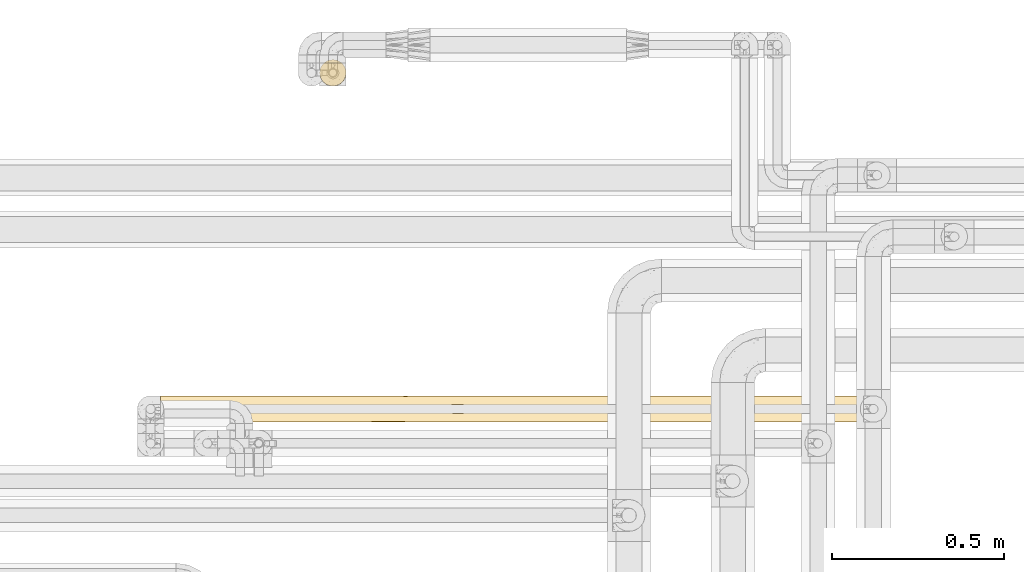
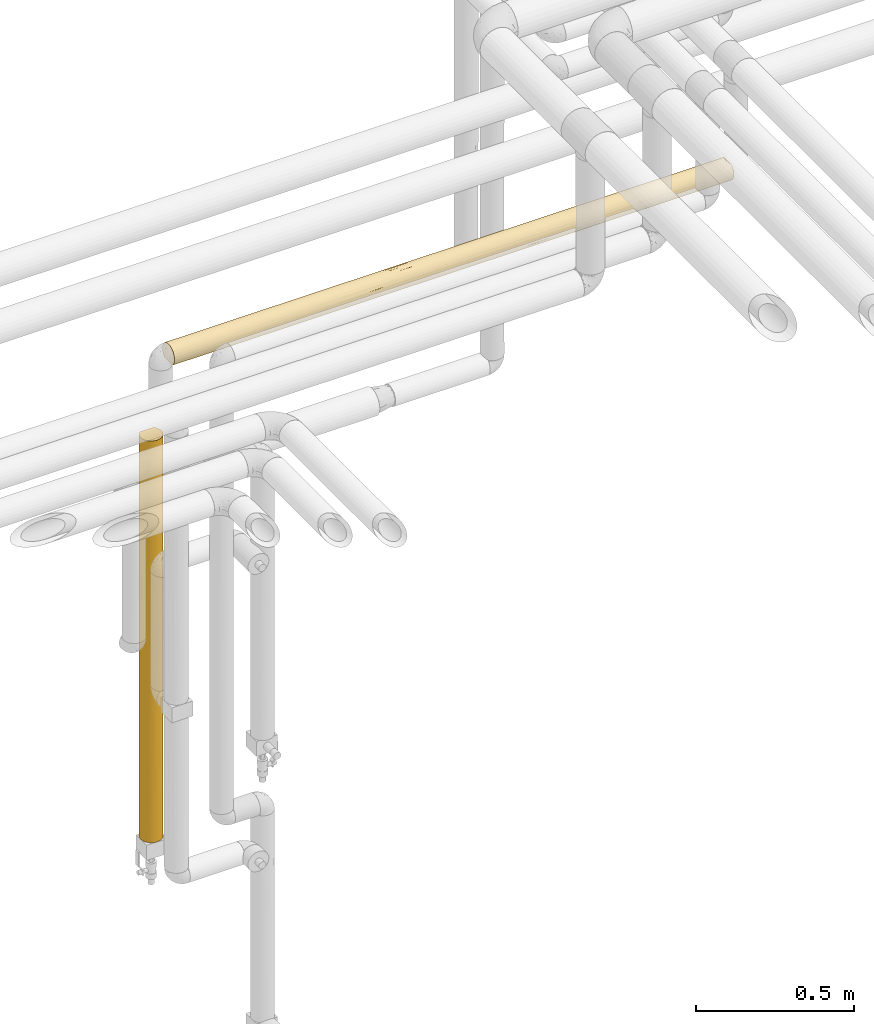
# One storey, part 43 of 827: 2 coverings.
"""IFC2X3 building model written with IfcOpenShell, lengths in millimetres."""

from ifc_helpers import new_model, entity, si_unit, converted_unit, derived_unit, direction, frame, origin, place, context, subcontext, project, spatial, faceted_brep, element, save


model = new_model("IFC2X3")

# Units and contexts
model_context = context("Model", 3, precision=0.01, world=origin(), true_north=direction((6.12303176911189e-17, 1.0)))
body_context = subcontext(model_context, "Body", "Model", "MODEL_VIEW")
ifc_project = project(units=[si_unit("LENGTHUNIT", "METRE", prefix="MILLI"), si_unit("AREAUNIT", "SQUARE_METRE"), si_unit("VOLUMEUNIT", "CUBIC_METRE"), converted_unit("PLANEANGLEUNIT", "DEGREE", entity("IfcRatioMeasure", 0.0174532925199433), si_unit("PLANEANGLEUNIT", "RADIAN"), dimensions=[0, 0, 0, 0, 0, 0, 0]), si_unit("MASSUNIT", "GRAM", prefix="KILO"), derived_unit("MASSDENSITYUNIT", [(si_unit("MASSUNIT", "GRAM", prefix="KILO"), 1), (si_unit("LENGTHUNIT", "METRE"), -3)]), derived_unit("MOMENTOFINERTIAUNIT", [(si_unit("LENGTHUNIT", "METRE"), 4)]), si_unit("TIMEUNIT", "SECOND"), si_unit("FREQUENCYUNIT", "HERTZ"), si_unit("THERMODYNAMICTEMPERATUREUNIT", "DEGREE_CELSIUS"), derived_unit("THERMALTRANSMITTANCEUNIT", [(si_unit("MASSUNIT", "GRAM", prefix="KILO"), 1), (si_unit("THERMODYNAMICTEMPERATUREUNIT", "KELVIN"), -1), (si_unit("TIMEUNIT", "SECOND"), -3)]), derived_unit("VOLUMETRICFLOWRATEUNIT", [(si_unit("LENGTHUNIT", "METRE"), 3), (si_unit("TIMEUNIT", "SECOND"), -1)]), derived_unit("MASSFLOWRATEUNIT", [(si_unit("MASSUNIT", "GRAM", prefix="KILO"), 1), (si_unit("TIMEUNIT", "SECOND"), -1)]), derived_unit("ROTATIONALFREQUENCYUNIT", [(si_unit("TIMEUNIT", "SECOND"), -1)]), si_unit("ELECTRICCURRENTUNIT", "AMPERE"), si_unit("ELECTRICVOLTAGEUNIT", "VOLT"), si_unit("POWERUNIT", "WATT"), si_unit("FORCEUNIT", "NEWTON", prefix="KILO"), si_unit("ILLUMINANCEUNIT", "LUX"), si_unit("LUMINOUSFLUXUNIT", "LUMEN"), si_unit("LUMINOUSINTENSITYUNIT", "CANDELA"), derived_unit("USERDEFINED", [(si_unit("MASSUNIT", "GRAM", prefix="KILO"), -1), (si_unit("LENGTHUNIT", "METRE"), -2), (si_unit("TIMEUNIT", "SECOND"), 3), (si_unit("LUMINOUSFLUXUNIT", "LUMEN"), 1)]), derived_unit("LINEARVELOCITYUNIT", [(si_unit("LENGTHUNIT", "METRE"), 1), (si_unit("TIMEUNIT", "SECOND"), -1)]), si_unit("PRESSUREUNIT", "PASCAL"), derived_unit("USERDEFINED", [(si_unit("LENGTHUNIT", "METRE"), -2), (si_unit("MASSUNIT", "GRAM", prefix="KILO"), 1), (si_unit("TIMEUNIT", "SECOND"), -2)]), derived_unit("LINEARFORCEUNIT", [(si_unit("MASSUNIT", "GRAM", prefix="KILO"), 1), (si_unit("LENGTHUNIT", "METRE"), 1), (si_unit("TIMEUNIT", "SECOND"), -2), (si_unit("LENGTHUNIT", "METRE"), -1)]), derived_unit("PLANARFORCEUNIT", [(si_unit("MASSUNIT", "GRAM", prefix="KILO"), 1), (si_unit("LENGTHUNIT", "METRE"), 1), (si_unit("TIMEUNIT", "SECOND"), -2), (si_unit("LENGTHUNIT", "METRE"), -2)])], contexts=[model_context])

# Site, building, storey
site_placement = place(None, origin())
site = spatial("IfcSite", under=ifc_project, at=site_placement, CompositionType="ELEMENT")
building_placement = place(site_placement, origin())
building = spatial("IfcBuilding", under=site, at=building_placement, CompositionType="ELEMENT")
storey_placement = place(building_placement, frame((0.0, 0.0, 28200.0)))
storey = spatial("IfcBuildingStorey", under=building, at=storey_placement, Name="08", CompositionType="ELEMENT", Elevation=28200.0)

# Coverings
covering_1_placement = place(storey_placement, frame((35016.04, 19373.44, 367.5)))
element("IfcCovering", 1, at=covering_1_placement, inside=storey, Name=":ADSK_", ObjectType=":ADSK_", PredefinedType="INSULATION", context=body_context, shape_type="Brep", body=[
    faceted_brep([(73.25, 20.8, 1553.4), (77.09, 30.06, 1553.4), (78.4, 40.0, 1553.4), (77.51, 48.2, 1553.4), (74.9, 56.01, 1553.4), (70.68, 63.08, 1553.4), (65.05, 69.1, 1553.4), (14.94, 69.1, 1553.4), (9.31, 63.08, 1553.4), (5.09, 56.01, 1553.4), (2.48, 48.2, 1553.4), (1.6, 40.0, 1553.4), (2.9, 30.06, 1553.4), (6.74, 20.8, 1553.4), (12.84, 12.84, 1553.4), (20.8, 6.74, 1553.4), (30.06, 2.9, 1553.4), (40.0, 1.6, 1553.4), (49.93, 2.9, 1553.4), (59.2, 6.74, 1553.4), (67.15, 12.84, 1553.4), (73.25, 20.8, 0.0), (67.15, 12.84, 0.0), (59.2, 6.74, 0.0), (49.93, 2.9, 0.0), (40.0, 1.6, 0.0), (30.06, 2.9, 0.0), (20.8, 6.74, 0.0), (12.84, 12.84, 0.0), (6.74, 20.8, 0.0), (2.9, 30.06, 0.0), (1.6, 40.0, 0.0), (2.9, 49.93, 0.0), (6.74, 59.2, 0.0), (12.84, 67.15, 0.0), (20.8, 73.25, 0.0), (30.06, 77.09, 0.0), (40.0, 78.4, 0.0), (49.93, 77.09, 0.0), (59.2, 73.25, 0.0), (67.15, 67.15, 0.0), (73.25, 59.2, 0.0), (77.09, 49.93, 0.0), (78.4, 40.0, 0.0), (77.09, 30.06, 0.0), (75.47, 54.69, 266.77), (48.24, 77.5, 1219.54), (50.46, 76.94, 866.93), (40.0, 78.4, 1111.35), (54.69, 75.47, 201.29), (63.37, 70.46, 294.69), (40.0, 78.4, 339.3), (46.91, 77.77, 217.05), (72.98, 59.66, 1336.34), (72.98, 59.66, 1069.82), (68.03, 66.24, 1267.75), (63.21, 70.58, 1148.14), (67.73, 66.56, 1010.86), (76.41, 52.17, 1267.76), (76.41, 52.18, 560.33), (78.4, 40.0, 687.91), (78.4, 40.0, 649.13), (78.4, 40.0, 432.75), (77.14, 49.74, 938.18), (77.72, 47.16, 324.56), (71.52, 61.92, 769.77), (70.46, 63.37, 464.2), (65.48, 68.72, 605.07), (40.0, 78.4, 1327.73), (40.0, 78.4, 1544.1), (46.78, 77.79, 1544.7), (70.46, 63.37, 209.5), (53.36, 76.0, 1546.5), (56.68, 74.58, 1170.0), (40.0, 78.4, 678.61), (50.88, 76.82, 642.02), (62.48, 71.13, 1360.94), (78.4, 40.0, 1337.03), (59.51, 73.07, 1549.43), (54.69, 75.47, 449.29), (47.02, 77.75, 447.87), (58.44, 73.68, 653.41), (78.4, 40.0, 1209.45), (78.4, 40.0, 1120.65), (56.87, 74.49, 846.14), (78.4, 40.0, 904.28), (78.4, 40.0, 865.5), (74.68, 56.47, 882.83), (78.4, 40.0, 216.37), (40.0, 78.4, 894.98), (62.77, 70.91, 837.81), (16.62, 70.46, 294.69), (10.67, 64.78, 880.34), (14.59, 68.79, 1054.68), (17.22, 70.91, 837.81), (31.91, 77.53, 325.29), (32.38, 77.63, 570.69), (25.3, 75.47, 201.29), (17.38, 71.03, 1238.47), (20.48, 73.07, 1549.43), (23.31, 74.58, 1170.0), (25.3, 75.47, 449.29), (26.63, 76.0, 1546.5), (9.53, 63.37, 209.5), (31.75, 77.5, 1219.54), (33.21, 77.79, 1544.7), (11.96, 66.24, 1267.75), (3.58, 52.17, 1267.76), (1.6, 40.0, 1337.03), (29.53, 76.94, 866.93), (9.26, 63.01, 677.18), (5.92, 57.7, 789.86), (2.85, 49.74, 938.18), (1.6, 40.0, 687.91), (1.6, 40.0, 904.28), (1.6, 40.0, 1120.65), (4.52, 54.69, 266.77), (7.01, 59.66, 1336.34), (7.01, 59.66, 1069.82), (3.58, 52.18, 560.33), (18.25, 71.64, 576.21), (23.1, 74.48, 854.76), (25.74, 75.65, 673.84), (1.6, 40.0, 432.75), (2.27, 47.16, 324.56), (1.6, 40.0, 216.37), (1.6, 40.0, 343.95), (9.53, 63.37, 464.2), (9.53, 16.62, 259.19), (16.62, 9.53, 324.27), (4.52, 25.3, 1148.08), (2.29, 32.71, 1228.84), (2.42, 32.07, 931.75), (4.48, 25.39, 946.02), (7.43, 19.65, 1024.07), (4.52, 25.3, 203.23), (2.46, 31.9, 328.02), (2.35, 32.43, 574.63), (40.0, 1.6, 216.38), (4.78, 24.68, 737.66), (4.52, 25.3, 452.8), (40.0, 1.6, 1209.45), (31.87, 2.47, 1215.19), (31.92, 2.45, 994.74), (9.53, 16.62, 1298.41), (16.62, 9.53, 1252.88), (17.37, 8.97, 551.38), (11.49, 14.27, 544.47), (25.3, 4.52, 245.05), (32.71, 2.29, 324.56), (25.3, 4.52, 529.72), (33.12, 2.22, 561.65), (27.96, 3.53, 808.58), (25.3, 4.52, 1342.94), (3.89, 26.92, 1358.75), (18.06, 8.48, 778.79), (9.53, 16.62, 829.74), (25.3, 4.52, 1087.44), (12.04, 13.67, 1064.08), (18.26, 8.34, 1019.38), (40.0, 1.6, 343.95), (40.0, 1.6, 432.75), (40.0, 1.6, 649.12), (40.0, 1.6, 687.91), (40.0, 1.6, 865.49), (40.0, 1.6, 1337.03), (40.0, 1.6, 904.28), (40.0, 1.6, 1120.65), (63.37, 9.53, 259.19), (70.46, 16.62, 324.27), (54.69, 4.52, 1148.08), (47.28, 2.29, 1228.84), (47.92, 2.42, 931.75), (54.6, 4.48, 946.02), (60.34, 7.43, 1024.07), (54.69, 4.52, 203.23), (48.09, 2.46, 328.02), (47.57, 2.35, 574.63), (55.31, 4.78, 737.66), (54.69, 4.52, 452.8), (77.53, 31.87, 1215.19), (77.54, 31.92, 994.74), (63.37, 9.53, 1298.41), (70.46, 16.62, 1252.88), (71.02, 17.37, 551.38), (65.72, 11.49, 544.47), (75.47, 25.3, 245.05), (77.7, 32.71, 324.56), (75.47, 25.3, 529.72), (77.77, 33.12, 561.65), (76.46, 27.96, 808.58), (75.47, 25.3, 1342.94), (53.07, 3.89, 1358.75), (71.51, 18.06, 778.79), (63.37, 9.53, 829.74), (75.47, 25.3, 1087.44), (66.32, 12.04, 1064.08), (71.65, 18.26, 1019.38)], [[[0, 1, 2, 3, 4, 5, 6, 7, 8, 9, 10, 11, 12, 13, 14, 15, 16, 17, 18, 19, 20]], [[21, 22, 23, 24, 25, 26, 27, 28, 29, 30, 31, 32, 33, 34, 35, 36, 37, 38, 39, 40, 41, 42, 43, 44]], [[42, 41, 45]], [[46, 47, 48]], [[49, 50, 39]], [[51, 52, 37]], [[53, 54, 55]], [[56, 55, 57]], [[58, 4, 3]], [[59, 60, 61, 62]], [[58, 63, 54]], [[57, 55, 54]], [[59, 62, 64]], [[65, 66, 67]], [[55, 5, 53]], [[68, 69, 70]], [[58, 53, 4]], [[41, 40, 71]], [[46, 72, 73]], [[70, 72, 46]], [[74, 47, 75]], [[56, 76, 55]], [[3, 2, 77]], [[38, 49, 39]], [[39, 50, 40]], [[5, 55, 6]], [[76, 72, 78]], [[63, 60, 59]], [[79, 80, 75]], [[81, 67, 50]], [[48, 68, 46]], [[79, 49, 52]], [[76, 78, 6]], [[58, 77, 82, 83]], [[63, 58, 83]], [[66, 59, 45]], [[64, 42, 45]], [[59, 66, 65]], [[70, 46, 68]], [[46, 73, 47]], [[84, 73, 56]], [[75, 81, 79]], [[50, 79, 81]], [[71, 50, 66]], [[63, 83, 85, 86, 60]], [[79, 52, 80]], [[87, 59, 65]], [[45, 41, 71]], [[42, 64, 88]], [[88, 64, 62]], [[3, 77, 58]], [[88, 43, 42]], [[59, 64, 45]], [[50, 71, 40]], [[45, 71, 66]], [[52, 49, 38]], [[50, 49, 79]], [[37, 52, 38]], [[52, 51, 80]], [[51, 74, 80]], [[47, 74, 89, 48]], [[74, 75, 80]], [[81, 84, 90]], [[84, 75, 47]], [[81, 90, 67]], [[90, 57, 65]], [[50, 67, 66]], [[90, 65, 67]], [[65, 54, 87]], [[75, 84, 81]], [[73, 84, 47]], [[65, 57, 54]], [[90, 84, 56]], [[90, 56, 57]], [[73, 72, 76]], [[55, 76, 6]], [[73, 76, 56]], [[4, 53, 5]], [[54, 53, 58]], [[54, 63, 87]], [[59, 87, 63]], [[34, 91, 35]], [[92, 93, 94]], [[51, 95, 96]], [[97, 95, 36]], [[98, 7, 99]], [[93, 98, 100]], [[91, 101, 97]], [[99, 102, 100]], [[34, 33, 103]], [[68, 104, 105]], [[97, 36, 35]], [[7, 106, 8]], [[104, 68, 48]], [[107, 108, 10]], [[104, 109, 100]], [[110, 111, 92]], [[112, 113, 114, 115]], [[32, 116, 33]], [[106, 117, 8]], [[118, 93, 92]], [[117, 9, 8]], [[9, 107, 10]], [[111, 119, 112]], [[115, 107, 112]], [[120, 94, 121]], [[102, 105, 104]], [[118, 107, 117]], [[96, 122, 109]], [[119, 123, 113]], [[112, 107, 118]], [[10, 108, 11]], [[119, 124, 123]], [[124, 125, 126, 123]], [[103, 116, 127]], [[105, 69, 68]], [[74, 96, 109]], [[104, 100, 102]], [[74, 51, 96]], [[121, 109, 122]], [[103, 91, 34]], [[110, 120, 127]], [[111, 112, 118]], [[36, 95, 37]], [[113, 112, 119]], [[125, 124, 32]], [[127, 116, 119]], [[32, 31, 125]], [[115, 108, 107]], [[119, 116, 124]], [[32, 124, 116]], [[116, 103, 33]], [[91, 103, 127]], [[91, 97, 35]], [[95, 97, 101]], [[95, 101, 96]], [[95, 51, 37]], [[122, 96, 101]], [[109, 48, 89, 74]], [[120, 122, 101]], [[122, 120, 121]], [[101, 91, 120]], [[127, 120, 91]], [[93, 121, 94]], [[100, 109, 121]], [[92, 111, 118]], [[119, 111, 110]], [[93, 118, 106]], [[94, 120, 110]], [[98, 93, 106]], [[121, 93, 100]], [[7, 98, 106]], [[99, 100, 98]], [[110, 92, 94]], [[119, 110, 127]], [[118, 117, 106]], [[9, 117, 107]], [[48, 109, 104]], [[128, 28, 129]], [[130, 131, 132]], [[133, 134, 130]], [[29, 28, 128]], [[135, 30, 29]], [[126, 136, 137]], [[26, 25, 138]], [[139, 137, 140]], [[12, 108, 131]], [[141, 142, 143]], [[144, 145, 14]], [[146, 147, 129]], [[148, 149, 150]], [[115, 131, 108]], [[151, 152, 150]], [[16, 15, 153]], [[154, 12, 131]], [[27, 26, 148]], [[27, 129, 28]], [[155, 156, 147]], [[145, 157, 153]], [[129, 148, 150]], [[16, 153, 142]], [[15, 14, 145]], [[135, 136, 30]], [[144, 158, 145]], [[148, 129, 27]], [[150, 149, 151]], [[147, 140, 128]], [[14, 13, 144]], [[16, 142, 17]], [[158, 155, 159]], [[147, 128, 129]], [[30, 136, 31]], [[135, 128, 140]], [[154, 144, 13]], [[158, 134, 156]], [[147, 146, 155]], [[147, 156, 139]], [[152, 155, 150]], [[158, 159, 145]], [[138, 149, 26]], [[149, 138, 160, 161]], [[149, 161, 151]], [[26, 149, 148]], [[152, 162, 163, 164]], [[142, 157, 143]], [[151, 162, 152]], [[152, 157, 159]], [[151, 161, 162]], [[12, 11, 108]], [[132, 131, 115]], [[131, 130, 154]], [[132, 115, 114, 113]], [[137, 113, 123, 126]], [[144, 154, 130]], [[13, 12, 154]], [[145, 153, 15]], [[142, 153, 157]], [[157, 152, 143]], [[142, 141, 165, 17]], [[152, 164, 143]], [[143, 164, 166, 167, 141]], [[134, 144, 130]], [[155, 158, 156]], [[152, 159, 155]], [[157, 145, 159]], [[128, 135, 29]], [[136, 135, 140]], [[136, 140, 137]], [[136, 126, 125, 31]], [[140, 147, 139]], [[132, 113, 137]], [[156, 134, 133]], [[132, 137, 139]], [[144, 134, 158]], [[130, 132, 133]], [[132, 139, 133]], [[156, 133, 139]], [[129, 150, 146]], [[150, 155, 146]], [[168, 22, 169]], [[170, 171, 172]], [[173, 174, 170]], [[23, 22, 168]], [[175, 24, 23]], [[160, 176, 177]], [[44, 43, 88]], [[178, 177, 179]], [[18, 165, 171]], [[82, 180, 181]], [[182, 183, 20]], [[184, 185, 169]], [[186, 187, 188]], [[171, 165, 141, 167]], [[189, 190, 188]], [[1, 0, 191]], [[192, 18, 171]], [[21, 44, 186]], [[21, 169, 22]], [[193, 194, 185]], [[183, 195, 191]], [[169, 186, 188]], [[1, 191, 180]], [[0, 20, 183]], [[175, 176, 24]], [[182, 196, 183]], [[186, 169, 21]], [[188, 187, 189]], [[185, 179, 168]], [[20, 19, 182]], [[1, 180, 2]], [[196, 193, 197]], [[185, 168, 169]], [[24, 176, 25]], [[175, 168, 179]], [[192, 182, 19]], [[196, 174, 194]], [[185, 184, 193]], [[185, 194, 178]], [[190, 193, 188]], [[196, 197, 183]], [[88, 187, 44]], [[187, 88, 62]], [[187, 62, 189]], [[44, 187, 186]], [[190, 61, 60, 86]], [[180, 195, 181]], [[189, 61, 190]], [[190, 195, 197]], [[189, 62, 61]], [[18, 17, 165]], [[172, 171, 167]], [[171, 170, 192]], [[172, 167, 166, 164, 163]], [[177, 163, 162, 161, 160]], [[182, 192, 170]], [[19, 18, 192]], [[183, 191, 0]], [[180, 191, 195]], [[195, 190, 181]], [[180, 82, 77, 2]], [[190, 86, 181]], [[181, 86, 85, 83, 82]], [[174, 182, 170]], [[193, 196, 194]], [[190, 197, 193]], [[195, 183, 197]], [[168, 175, 23]], [[176, 175, 179]], [[176, 179, 177]], [[176, 160, 138, 25]], [[179, 185, 178]], [[172, 163, 177]], [[194, 174, 173]], [[172, 177, 178]], [[182, 174, 196]], [[170, 172, 173]], [[172, 178, 173]], [[194, 173, 178]], [[169, 188, 184]], [[188, 193, 184]], [[78, 72, 70, 69, 105, 102, 99, 7, 6]]]),
])
covering_2_placement = place(storey_placement, frame((34552.89, 18394.91, 2960.17)))
element("IfcCovering", 2, at=covering_2_placement, inside=storey, Name=":ADSK_", ObjectType=":ADSK_", PredefinedType="INSULATION", context=body_context, shape_type="Brep", body=[
    faceted_brep([(1.6, 2.48, 31.79), (1.6, 1.6, 40.0), (1.6, 2.9, 49.93), (1.6, 6.74, 59.2), (1.6, 12.84, 67.15), (1.6, 20.8, 73.25), (1.6, 30.06, 77.09), (1.6, 40.0, 78.4), (1.6, 49.93, 77.09), (1.6, 59.2, 73.25), (1.6, 67.15, 67.15), (1.6, 73.25, 59.2), (1.6, 77.09, 49.93), (1.6, 78.4, 40.0), (1.6, 77.51, 31.79), (1.6, 74.9, 23.98), (1.6, 70.68, 16.91), (1.6, 65.05, 10.9), (1.6, 14.94, 10.9), (1.6, 9.31, 16.91), (1.6, 5.09, 23.98), (2047.65, 2.9, 30.06), (2047.65, 6.74, 20.8), (2047.65, 12.84, 12.84), (2047.65, 20.8, 6.74), (2047.65, 30.06, 2.9), (2047.65, 40.0, 1.6), (2047.65, 49.93, 2.9), (2047.65, 59.2, 6.74), (2047.65, 67.15, 12.84), (2047.65, 73.25, 20.8), (2047.65, 77.09, 30.06), (2047.65, 78.4, 40.0), (2047.65, 77.51, 48.2), (2047.65, 74.9, 56.01), (2047.65, 70.68, 63.08), (2047.65, 65.05, 69.1), (2047.65, 14.94, 69.1), (2047.65, 9.31, 63.08), (2047.65, 5.09, 56.01), (2047.65, 2.48, 48.2), (2047.65, 1.6, 40.0), (1765.79, 63.37, 9.53), (1795.06, 70.46, 16.62), (335.45, 48.24, 2.49), (688.07, 50.46, 3.05), (443.64, 40.0, 1.6), (1614.91, 40.0, 1.6), (1723.09, 47.32, 2.3), (1831.28, 40.0, 1.6), (858.72, 56.53, 5.34), (938.12, 48.56, 2.56), (1655.41, 75.47, 25.3), (1544.61, 72.51, 19.56), (1278.42, 76.56, 28.25), (1604.94, 77.8, 33.26), (1457.37, 78.4, 40.0), (717.19, 62.77, 9.08), (544.14, 67.73, 13.43), (785.68, 68.8, 14.61), (706.89, 73.03, 20.41), (928.51, 72.9, 20.2), (287.23, 76.41, 27.82), (218.66, 72.98, 20.33), (485.18, 72.98, 20.33), (616.82, 77.14, 30.25), (5.57, 59.51, 6.92), (194.06, 62.48, 8.86), (8.5, 53.36, 4.0), (1614.9, 78.4, 40.0), (1752.51, 78.4, 40.0), (406.86, 63.21, 9.41), (287.24, 68.03, 13.75), (1832.41, 77.68, 32.62), (1876.89, 75.52, 25.42), (1431.19, 47.83, 2.4), (1637.34, 54.69, 4.52), (10.29, 46.78, 2.2), (1438.21, 62.59, 8.95), (1353.89, 70.46, 16.62), (1574.48, 67.95, 13.67), (217.97, 78.4, 40.0), (1852.26, 53.24, 3.95), (227.27, 40.0, 1.6), (10.9, 40.0, 1.6), (660.01, 40.0, 1.6), (876.39, 40.0, 1.6), (384.99, 56.68, 5.41), (296.74, 78.4, 40.0), (434.34, 78.4, 40.0), (606.06, 57.11, 5.62), (1078.35, 64.63, 10.54), (867.09, 78.4, 40.0), (591.87, 78.4, 40.0), (650.71, 78.4, 40.0), (918.45, 77.02, 29.79), (887.01, 78.4, 40.0), (1162.23, 78.4, 40.0), (1119.35, 70.21, 16.29), (1402.29, 55.57, 4.9), (1160.52, 53.12, 3.91), (1134.3, 74.33, 22.8), (1245.65, 40.0, 1.6), (1831.28, 78.4, 40.0), (1182.15, 78.4, 40.0), (1398.52, 78.4, 40.0), (1852.26, 26.75, 3.95), (1637.34, 25.3, 4.52), (1723.09, 32.67, 2.3), (1402.29, 24.42, 4.9), (1078.35, 15.36, 10.54), (1160.52, 26.87, 3.91), (1431.19, 32.16, 2.4), (858.72, 23.46, 5.34), (606.06, 22.88, 5.62), (688.07, 29.53, 3.05), (1765.79, 16.62, 9.53), (1574.48, 8.07, 18.65), (1353.89, 9.53, 16.62), (1517.45, 12.4, 13.29), (938.12, 31.43, 2.56), (8.5, 26.63, 4.0), (384.99, 23.31, 5.41), (194.06, 17.51, 8.86), (287.23, 3.58, 27.82), (616.82, 2.85, 30.25), (434.34, 1.6, 40.0), (335.45, 31.75, 2.49), (10.29, 33.21, 2.2), (406.86, 16.78, 9.41), (1819.35, 2.77, 30.55), (1831.28, 1.6, 40.0), (1752.51, 1.6, 40.0), (217.97, 1.6, 40.0), (1860.89, 5.18, 23.8), (785.68, 11.19, 14.61), (1119.35, 9.78, 16.29), (1134.3, 5.66, 22.8), (1278.42, 3.44, 28.25), (218.66, 7.01, 20.33), (287.24, 11.96, 13.75), (544.14, 12.26, 13.43), (485.18, 7.01, 20.33), (918.45, 2.98, 29.79), (706.89, 6.96, 20.41), (1795.06, 9.53, 16.62), (1604.94, 2.19, 33.26), (1655.41, 4.52, 25.3), (5.57, 20.48, 6.92), (717.19, 17.22, 9.08), (1438.21, 17.4, 8.95), (867.09, 1.6, 40.0), (650.71, 1.6, 40.0), (591.88, 1.6, 40.0), (1614.91, 1.6, 40.0), (1457.37, 1.6, 40.0), (296.74, 1.6, 40.0), (1162.23, 1.6, 40.0), (928.51, 7.09, 20.2), (1398.53, 1.6, 40.0), (1182.16, 1.6, 40.0), (887.02, 1.6, 40.0), (1830.59, 7.01, 59.66), (1564.07, 7.01, 59.66), (1762.01, 3.58, 52.17), (283.46, 16.62, 70.46), (1855.19, 17.51, 71.13), (1664.26, 23.31, 74.58), (1642.39, 16.78, 70.58), (2040.75, 26.63, 76.0), (2038.96, 33.21, 77.79), (1713.79, 31.75, 77.5), (1190.52, 23.46, 74.65), (1443.19, 22.88, 74.37), (1361.18, 29.53, 76.94), (1432.43, 2.85, 49.74), (1762.01, 11.96, 66.24), (1505.11, 12.26, 66.56), (196.99, 26.75, 76.04), (326.15, 32.67, 77.69), (254.19, 9.53, 63.37), (646.96, 24.42, 75.09), (970.9, 15.36, 69.45), (888.73, 26.87, 76.08), (1821.98, 40.0, 78.4), (1111.13, 31.43, 77.43), (411.91, 25.3, 75.47), (618.06, 32.16, 77.59), (229.9, 2.77, 49.44), (188.36, 5.18, 56.19), (474.77, 8.07, 61.34), (695.35, 9.53, 63.37), (531.8, 12.4, 66.7), (1263.57, 11.19, 65.39), (929.9, 9.78, 63.7), (217.97, 40.0, 78.4), (914.95, 5.66, 57.19), (770.83, 3.44, 51.74), (1605.61, 40.0, 78.4), (1130.79, 2.98, 50.2), (1342.35, 6.96, 59.58), (444.31, 2.19, 46.73), (393.84, 4.52, 54.69), (2043.68, 20.48, 73.07), (1332.06, 17.22, 70.91), (2038.35, 40.0, 78.4), (1389.23, 40.0, 78.4), (1172.86, 40.0, 78.4), (434.34, 40.0, 78.4), (611.04, 17.4, 71.04), (803.6, 40.0, 78.4), (1120.74, 7.09, 59.79), (1762.01, 68.03, 66.24), (1642.39, 63.21, 70.58), (1855.19, 62.48, 71.13), (1762.01, 76.41, 52.17), (1830.59, 72.98, 59.66), (1505.11, 67.73, 66.56), (2038.96, 46.78, 77.79), (1713.79, 48.24, 77.5), (283.46, 63.37, 70.46), (2043.68, 59.51, 73.07), (2040.75, 53.36, 76.0), (254.19, 70.46, 63.37), (1111.13, 48.56, 77.43), (1361.18, 50.46, 76.94), (1190.52, 56.53, 74.65), (618.06, 47.83, 77.59), (411.91, 54.69, 75.47), (326.15, 47.32, 77.69), (1120.74, 72.9, 59.79), (1263.57, 68.8, 65.39), (1342.35, 73.03, 59.58), (444.31, 77.8, 46.73), (1564.07, 72.98, 59.66), (1432.43, 77.14, 49.74), (770.83, 76.56, 51.74), (393.84, 75.47, 54.69), (216.84, 77.68, 47.37), (172.36, 75.52, 54.57), (196.99, 53.24, 76.04), (1332.06, 62.77, 70.91), (611.04, 62.59, 71.04), (695.35, 70.46, 63.37), (474.77, 67.95, 66.32), (504.64, 72.51, 60.43), (1664.26, 56.68, 74.58), (1443.19, 57.11, 74.37), (970.9, 64.63, 69.45), (1130.79, 77.02, 50.2), (929.9, 70.21, 63.7), (646.96, 55.57, 75.09), (888.73, 53.12, 76.08), (914.95, 74.33, 57.19)], [[[0, 1, 2, 3, 4, 5, 6, 7, 8, 9, 10, 11, 12, 13, 14, 15, 16, 17, 18, 19, 20]], [[21, 22, 23, 24, 25, 26, 27, 28, 29, 30, 31, 32, 33, 34, 35, 36, 37, 38, 39, 40, 41]], [[42, 43, 29]], [[44, 45, 46]], [[47, 48, 49]], [[45, 50, 51]], [[43, 30, 29]], [[49, 48, 27]], [[52, 53, 54]], [[55, 54, 56]], [[57, 58, 59]], [[59, 60, 61]], [[62, 63, 15]], [[64, 62, 65]], [[66, 67, 68]], [[55, 56, 69, 70]], [[71, 72, 58]], [[52, 73, 74]], [[75, 76, 48]], [[77, 68, 44]], [[78, 79, 80]], [[71, 67, 72]], [[14, 13, 81]], [[63, 72, 16]], [[82, 42, 28]], [[16, 72, 17]], [[72, 63, 64]], [[82, 27, 48]], [[83, 84, 77]], [[62, 15, 14]], [[28, 42, 29]], [[85, 46, 45, 86]], [[44, 68, 87]], [[46, 83, 44]], [[52, 55, 73]], [[58, 72, 64]], [[67, 66, 17]], [[62, 81, 88, 89]], [[65, 62, 89]], [[77, 44, 83]], [[44, 87, 45]], [[87, 90, 45]], [[47, 75, 48]], [[90, 50, 45]], [[78, 91, 79]], [[78, 42, 76]], [[53, 43, 80]], [[92, 65, 89, 93, 94]], [[95, 92, 96, 97]], [[65, 92, 95]], [[98, 79, 91]], [[76, 75, 99]], [[31, 73, 32]], [[14, 81, 62]], [[100, 50, 91]], [[91, 78, 99]], [[91, 57, 59]], [[42, 78, 80]], [[74, 43, 52]], [[101, 79, 98]], [[61, 60, 95]], [[27, 26, 49]], [[75, 47, 102]], [[48, 76, 82]], [[102, 86, 51]], [[102, 100, 75]], [[76, 99, 78]], [[42, 82, 76]], [[28, 27, 82]], [[60, 59, 58]], [[57, 90, 71]], [[60, 58, 64]], [[59, 61, 98]], [[64, 65, 60]], [[95, 60, 65]], [[57, 71, 58]], [[87, 68, 67]], [[72, 67, 17]], [[87, 67, 71]], [[73, 55, 70]], [[54, 55, 52]], [[73, 70, 103, 32]], [[73, 31, 74]], [[31, 30, 74]], [[43, 74, 30]], [[75, 100, 99]], [[91, 99, 100]], [[15, 63, 16]], [[64, 63, 62]], [[95, 97, 54]], [[101, 95, 54]], [[54, 97, 104, 105, 56]], [[71, 90, 87]], [[50, 90, 57]], [[91, 50, 57]], [[45, 51, 86]], [[50, 100, 51]], [[102, 51, 100]], [[59, 98, 91]], [[101, 98, 61]], [[95, 101, 61]], [[79, 101, 54]], [[53, 80, 79]], [[42, 80, 43]], [[54, 53, 79]], [[43, 53, 52]], [[106, 107, 108]], [[109, 110, 111]], [[112, 108, 107]], [[113, 114, 115]], [[116, 24, 23]], [[117, 118, 119]], [[113, 115, 120]], [[121, 122, 123]], [[124, 125, 126]], [[83, 127, 128]], [[122, 129, 123]], [[130, 41, 131, 132]], [[107, 106, 116]], [[124, 133, 0]], [[83, 46, 127]], [[20, 124, 0]], [[134, 21, 130]], [[135, 110, 136]], [[137, 118, 138]], [[139, 19, 140]], [[140, 141, 142]], [[139, 142, 124]], [[18, 140, 19]], [[139, 20, 19]], [[25, 106, 108]], [[143, 125, 144]], [[49, 26, 25]], [[116, 23, 145]], [[121, 128, 127]], [[127, 115, 122]], [[146, 130, 132]], [[147, 146, 138]], [[123, 18, 148]], [[129, 149, 141]], [[125, 124, 142]], [[0, 133, 1]], [[128, 84, 83]], [[115, 46, 85, 86]], [[127, 122, 121]], [[47, 108, 112]], [[114, 122, 115]], [[150, 107, 116]], [[114, 113, 149]], [[23, 22, 145]], [[117, 119, 145]], [[142, 141, 144]], [[125, 151, 152, 153, 126]], [[141, 135, 144]], [[117, 138, 118]], [[110, 150, 118]], [[146, 132, 154, 155]], [[124, 126, 156, 133]], [[120, 102, 111]], [[136, 110, 118]], [[110, 149, 113]], [[134, 145, 22]], [[117, 145, 147]], [[157, 143, 138]], [[136, 137, 158]], [[25, 108, 49]], [[47, 49, 108]], [[102, 47, 112]], [[107, 109, 112]], [[109, 107, 150]], [[111, 102, 112]], [[25, 24, 106]], [[116, 106, 24]], [[129, 141, 140]], [[135, 141, 149]], [[110, 135, 149]], [[135, 158, 144]], [[143, 144, 158]], [[125, 142, 144]], [[140, 18, 123]], [[129, 122, 114]], [[123, 148, 121]], [[140, 123, 129]], [[138, 146, 155]], [[130, 146, 147]], [[134, 130, 147]], [[130, 21, 41]], [[145, 134, 147]], [[21, 134, 22]], [[110, 109, 150]], [[111, 112, 109]], [[142, 139, 140]], [[20, 139, 124]], [[137, 143, 158]], [[138, 155, 159, 160, 157]], [[46, 115, 127]], [[143, 157, 161, 151]], [[129, 114, 149]], [[120, 115, 86]], [[110, 113, 111]], [[102, 120, 86]], [[111, 113, 120]], [[151, 125, 143]], [[135, 136, 158]], [[118, 137, 136]], [[143, 137, 138]], [[138, 117, 147]], [[119, 118, 150]], [[150, 116, 119]], [[145, 119, 116]], [[162, 163, 164]], [[165, 5, 4]], [[166, 167, 168]], [[169, 170, 171]], [[172, 173, 174]], [[162, 39, 38]], [[164, 131, 40]], [[164, 175, 154]], [[176, 177, 163]], [[38, 176, 162]], [[6, 178, 179]], [[171, 174, 167]], [[4, 180, 165]], [[181, 182, 183]], [[184, 171, 170]], [[174, 185, 172]], [[179, 186, 187]], [[188, 1, 133, 156]], [[2, 188, 189]], [[166, 169, 167]], [[37, 176, 38]], [[190, 191, 192]], [[193, 182, 194]], [[165, 186, 178]], [[178, 186, 179]], [[195, 7, 6]], [[196, 191, 197]], [[184, 198, 171]], [[39, 164, 40]], [[199, 175, 200]], [[201, 188, 156]], [[202, 201, 197]], [[166, 37, 203]], [[168, 204, 177]], [[175, 164, 163]], [[40, 131, 41]], [[170, 205, 184]], [[174, 198, 206, 207]], [[171, 167, 169]], [[208, 179, 187]], [[173, 167, 174]], [[209, 186, 165]], [[173, 172, 204]], [[4, 3, 180]], [[190, 192, 180]], [[163, 177, 200]], [[175, 160, 159, 155, 154]], [[177, 193, 200]], [[190, 197, 191]], [[182, 209, 191]], [[201, 156, 126, 153]], [[164, 154, 132, 131]], [[185, 210, 183]], [[194, 182, 191]], [[182, 204, 172]], [[189, 180, 3]], [[190, 180, 202]], [[161, 199, 197]], [[194, 196, 211]], [[6, 179, 195]], [[208, 195, 179]], [[210, 208, 187]], [[186, 181, 187]], [[181, 186, 209]], [[183, 210, 187]], [[6, 5, 178]], [[165, 178, 5]], [[168, 177, 176]], [[193, 177, 204]], [[182, 193, 204]], [[193, 211, 200]], [[199, 200, 211]], [[175, 163, 200]], [[176, 37, 166]], [[168, 167, 173]], [[166, 203, 169]], [[176, 166, 168]], [[197, 201, 153]], [[188, 201, 202]], [[189, 188, 202]], [[188, 2, 1]], [[180, 189, 202]], [[2, 189, 3]], [[182, 181, 209]], [[183, 187, 181]], [[163, 162, 176]], [[39, 162, 164]], [[196, 199, 211]], [[197, 153, 152, 151, 161]], [[198, 174, 171]], [[199, 161, 157, 160]], [[168, 173, 204]], [[185, 174, 207]], [[182, 172, 183]], [[210, 185, 207]], [[183, 172, 185]], [[160, 175, 199]], [[193, 194, 211]], [[191, 196, 194]], [[199, 196, 197]], [[197, 190, 202]], [[192, 191, 209]], [[209, 165, 192]], [[180, 192, 165]], [[212, 213, 214]], [[215, 103, 70, 69]], [[216, 212, 35]], [[213, 212, 217]], [[35, 212, 36]], [[215, 216, 34]], [[218, 219, 184]], [[9, 220, 10]], [[221, 214, 222]], [[220, 223, 10]], [[224, 225, 226]], [[223, 11, 10]], [[215, 34, 33]], [[227, 228, 229]], [[195, 229, 8]], [[206, 198, 225, 207]], [[230, 231, 232]], [[233, 93, 89, 88]], [[234, 215, 235]], [[233, 236, 93]], [[237, 238, 239]], [[218, 222, 219]], [[240, 8, 229]], [[208, 229, 195]], [[9, 240, 220]], [[241, 217, 231]], [[242, 243, 244]], [[212, 216, 234]], [[184, 205, 218]], [[198, 219, 225]], [[237, 245, 236]], [[237, 233, 238]], [[217, 212, 234]], [[214, 221, 36]], [[215, 33, 103]], [[235, 215, 69]], [[219, 222, 246]], [[198, 184, 219]], [[219, 246, 225]], [[246, 247, 225]], [[208, 227, 229]], [[247, 226, 225]], [[242, 248, 243]], [[242, 220, 228]], [[245, 223, 244]], [[104, 235, 69, 56, 105]], [[249, 104, 97, 96]], [[235, 104, 249]], [[250, 243, 248]], [[33, 32, 103]], [[12, 238, 13]], [[228, 227, 251]], [[252, 226, 248]], [[248, 242, 251]], [[248, 241, 231]], [[220, 242, 244]], [[239, 223, 237]], [[253, 243, 250]], [[230, 232, 249]], [[8, 7, 195]], [[227, 208, 210]], [[229, 228, 240]], [[210, 207, 224]], [[210, 252, 227]], [[228, 251, 242]], [[220, 240, 228]], [[9, 8, 240]], [[232, 231, 217]], [[241, 247, 213]], [[232, 217, 234]], [[231, 230, 250]], [[234, 235, 232]], [[249, 232, 235]], [[241, 213, 217]], [[246, 222, 214]], [[212, 214, 36]], [[246, 214, 213]], [[238, 233, 88]], [[236, 233, 237]], [[238, 88, 81, 13]], [[238, 12, 239]], [[12, 11, 239]], [[223, 239, 11]], [[227, 252, 251]], [[248, 251, 252]], [[34, 216, 35]], [[234, 216, 215]], [[249, 96, 236]], [[253, 249, 236]], [[236, 96, 92, 94, 93]], [[213, 247, 246]], [[226, 247, 241]], [[248, 226, 241]], [[225, 224, 207]], [[226, 252, 224]], [[210, 224, 252]], [[231, 250, 248]], [[253, 250, 230]], [[249, 253, 230]], [[243, 253, 236]], [[245, 244, 243]], [[220, 244, 223]], [[236, 245, 243]], [[223, 245, 237]], [[17, 66, 68, 77, 84, 128, 121, 148, 18]], [[205, 170, 169, 203, 37, 36, 221, 222, 218]]]),
])

save(model, "model.ifc")
